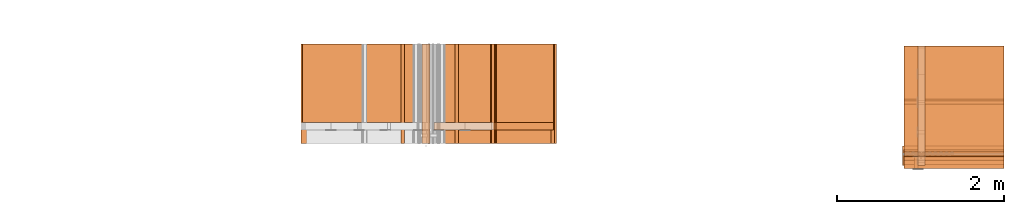
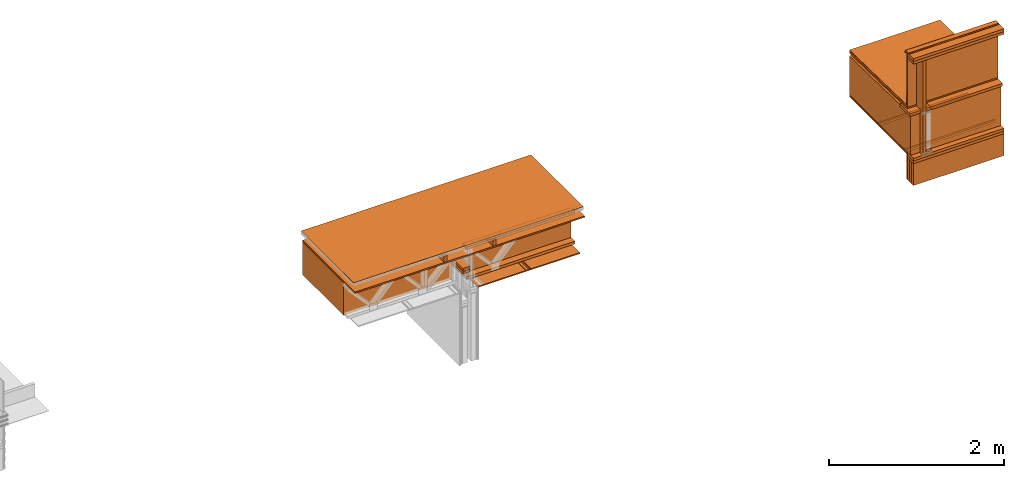
# One storey, part 5 of 22: 34 proxies.
"""IFC2X3 building model written with IfcOpenShell, lengths in feet."""

from ifc_helpers import new_model, entity, si_unit, converted_unit, frame, frame_2d, origin_with_axes, place, context, subcontext, project, spatial, polyline, rectangle, outline, extrude, element, save


model = new_model("IFC2X3")

# Units and contexts
model_context = context("Model", 3, precision=1e-05)
plan_context = context("Plan", 2, precision=1e-05, world=frame_2d((0.0, 0.0, 0.0), x_axis=(1.0, 0.0, 0.0)))
body_context_1 = subcontext(model_context, "Body", "Model", "MODEL_VIEW")
body_context_2 = subcontext(model_context, "Body", "Model", "MODEL_VIEW")
ifc_project = project(units=[converted_unit("VOLUMEUNIT", "cubic foot", entity("IfcReal", 0.0283168467116885), si_unit("VOLUMEUNIT", "CUBIC_METRE"), dimensions=[3, 0, 0, 0, 0, 0, 0]), converted_unit("AREAUNIT", "square foot", entity("IfcReal", 0.09290304), si_unit("AREAUNIT", "SQUARE_METRE"), dimensions=[2, 0, 0, 0, 0, 0, 0]), converted_unit("LENGTHUNIT", "foot", entity("IfcReal", 0.3048), si_unit("LENGTHUNIT", "METRE"), dimensions=[1, 0, 0, 0, 0, 0, 0])], contexts=[model_context, plan_context])

# Site, building, storey
site_placement = place(None, origin_with_axes())
site = spatial("IfcSite", under=ifc_project, at=site_placement, CompositionType="ELEMENT")
building_placement = place(site_placement, origin_with_axes())
building = spatial("IfcBuilding", under=site, at=building_placement, Name="Building", CompositionType="ELEMENT")
storey_placement = place(building_placement, origin_with_axes())
storey = spatial("IfcBuildingStorey", under=building, at=storey_placement, Name="Storey", CompositionType="ELEMENT")

# Proxies
proxy_1_placement = place(storey_placement, frame((1658.61945765538, 1.89104828778214, -61.6842117209447), z_axis=(0.0, 0.0, 1.0), x_axis=(-1.62920684942947e-07, 1.0, 0.0)))
element("IfcBuildingElementProxy", 1, at=proxy_1_placement, inside=storey, Name="Dowel60:Dowel", context=body_context_1, shape_type="SweptSolid", body=[
    extrude(outline(polyline([(-0.0916404852501833, -0.0212016241048069), (0.0303085609840283, -0.0212016241048069), (0.0667668820366146, 0.0152567168086611), (0.106276188955063, 0.015256727502982), (0.106276188955063, 0.020465054280391), (0.0646095380695473, 0.0204650527526309), (0.0281511925727989, -0.0159932835775567), (-0.0894831229499945, -0.0159932881608371), (-0.108790979903983, 0.00331455657107076), (-0.112473822915022, -0.00036828794385694), (-0.0916404852501833, -0.0212016241048069)])), frame((7.80471750220128e-07, -0.112483172807011, 0.0211991888551613), z_axis=(-1.0, -2.10234702535672e-05, -1.15315297080087e-05), x_axis=(2.10234720725566e-05, -1.0, -1.98194598510781e-08)), (1.86355100595392e-05, -1.09133670775918e-05, -1.0), 3.92583333463605),
])
proxy_2_placement = place(storey_placement, frame((1652.54157359206, 1.89104789667555, -61.7362946037232), z_axis=(0.0, 0.0, 1.0), x_axis=(1.0, 0.0, 0.0)))
element("IfcBuildingElementProxy", 2, at=proxy_2_placement, inside=storey, Name="Generic Models 847:Generic Models 1:245", context=body_context_1, shape_type="SweptSolid", body=[
    extrude(rectangle(XDim=4.43021606574954, YDim=3.92583333372057, at=frame_2d((0.0, 0.0, 0.0))), frame((6.22892942954236, 1.96291666644139, 0.0), z_axis=(0.0, 0.0, -1.0), x_axis=(0.999999940395355, 0.0, 0.0)), (0.0, 0.0, -1.0), 0.0520833335148361),
])
proxy_3_placement = place(storey_placement, frame((1651.993298468, 7.65793749040819, -59.9454707048071), z_axis=(-3.89414367418794e-07, 1.0, -1.62920684942947e-07), x_axis=(-1.0, -3.89414367418794e-07, -7.36919087627715e-15)))
element("IfcBuildingElementProxy", 3, at=proxy_3_placement, inside=storey, Name="Plane", context=body_context_1, shape_type="SweptSolid", body=[
    extrude(outline(polyline([(-2.35047103382471, -0.749991038261749), (2.35047924706316, -0.749991038261749), (2.3504714249313, 0.750003358119429), (-2.35047905150987, 0.749978327297476), (-2.35047103382471, -0.749991038261749)])), frame((-1.56912082449345, -0.947072632669464, -4.94139009886213), z_axis=(0.0, 0.0, -1.0), x_axis=(1.0, 5.3246303650667e-06, 0.0)), (1.39559645617737e-07, -7.72574892948796e-08, -1.0), 3.10033562211462),
])
proxy_4_placement = place(storey_placement, frame((1654.28802410136, 1.89106295427938, -60.0035359540324), z_axis=(-0.0623933188617229, 0.998051643371582, -7.58967132696853e-07), x_axis=(-0.998051643371582, -0.0623933188617229, -1.47461420851869e-07)))
element("IfcBuildingElementProxy", 4, at=proxy_4_placement, inside=storey, Name="Generic Models 849:Generic Models 1", context=body_context_1, shape_type="SweptSolid", body=[
    extrude(outline(polyline([(4.98456513787818, 7.67908338258737e-09), (4.98456474677158, 0.00935665461946074), (-4.98488115200533, 0.000311636831802365), (-4.98424795043124, -0.00966831004696842), (4.98456513787818, 7.67908338258737e-09)])), frame((-1.85528217651087, 0.365522404120663, -0.115972784716939), z_axis=(0.0623999424278736, 1.66406334756175e-05, -0.998051285743713), x_axis=(-0.998050689697266, -0.000969853426795453, -0.0623999498784542)), (6.8706026468135e-06, 1.65439741977025e-05, -1.0), 3.92583366120034),
])
proxy_5_placement = place(storey_placement, frame((1654.36702137544, 1.89104789667555, -60.1425383660424), z_axis=(0.0, 0.0, 1.0), x_axis=(1.0, 0.0, 0.0)))
element("IfcBuildingElementProxy", 5, at=proxy_5_placement, inside=storey, Name="Generic Models 841:Generic Models 1:245", context=body_context_1, shape_type="SweptSolid", body=[
    extrude(rectangle(XDim=9.96871498681381, YDim=3.92583333372057, at=frame_2d((0.0, 0.0, 0.0))), frame((1.84589288053237, 1.96291666644139, 0.0), z_axis=(0.0, 0.0, -1.0), x_axis=(-1.0, 0.0, 0.0)), (0.0, 0.0, -1.0), 0.0625000001175565),
])
proxy_6_placement = place(storey_placement, frame((1657.15966011908, 0.875493770665697, -59.9454707048071), z_axis=(0.0, 0.0, 1.0), x_axis=(1.0, 0.0, 0.0)))
element("IfcBuildingElementProxy", 6, at=proxy_6_placement, inside=storey, Name="Plane", context=body_context_1, shape_type="SweptSolid", body=[
    extrude(rectangle(XDim=3.10033562211458, YDim=4.70094978133192, at=frame_2d((0.0, 0.0, 0.0))), frame((1.56912062894015, 3.39122229986616, -1.69706332871294), z_axis=(0.0, 0.0, -1.0), x_axis=(0.0, -1.0, 0.0)), (0.0, 0.0, -1.0), 1.49999431547957),
])
proxy_7_placement = place(storey_placement, frame((1656.378297981, 1.89104809222885, -61.6425416600986), z_axis=(0.0, 0.0, 1.0), x_axis=(1.0, 0.0, 0.0)))
element("IfcBuildingElementProxy", 7, at=proxy_7_placement, inside=storey, Name="Generic Models 855:Generic Models 1", context=body_context_1, shape_type="SweptSolid", body=[
    extrude(rectangle(XDim=0.291666561478815, YDim=4.701001915869, at=frame_2d((0.0, 0.0, 0.0))), frame((2.35049430466699, 0.679666601766751, 8.21173307247166e-06), z_axis=(0.0, 0.0, -1.0), x_axis=(0.0, 1.0, 0.0)), (0.0, 0.0, -1.0), 0.125000015272121),
])
proxy_8_placement = place(storey_placement, frame((1656.378297981, 2.42488140978525, -60.1425383660424), z_axis=(0.0, 0.0, 1.0), x_axis=(1.0, 0.0, 0.0)))
element("IfcBuildingElementProxy", 8, at=proxy_8_placement, inside=storey, Name="Generic Models 855:Generic Models 1", context=body_context_1, shape_type="SweptSolid", body=[
    extrude(rectangle(XDim=0.291666664589754, YDim=4.701001915869, at=frame_2d((0.0, 0.0, 0.0))), frame((2.35051346889005, 0.145833333098669, -0.124997667127394), z_axis=(0.0, 0.0, -1.0), x_axis=(0.0, 1.0, 0.0)), (0.0, 0.0, -1.0), 0.125000015272121),
])
for number, where, z_axis, x_axis, name in (
    (9, (1657.09778392722, 1.89105591436071, -59.7883459777031), (1.0, 4.01339377731347e-07, -4.01339264044509e-07), (-4.01339264044509e-07, 1.0, 2.68220873067548e-07), "Generic Models 857:Generic Models 1"),
    (10, (1654.97266714341, 1.89105591436071, -59.7883459777031), (1.0, 4.01339377731347e-07, -4.01339264044509e-07), (-4.01339264044509e-07, 1.0, 2.68220873067548e-07), "Generic Models 857:Generic Models 1"),
):
    element("IfcBuildingElementProxy", number, at=place(storey_placement, frame(where, z_axis=z_axis, x_axis=x_axis)), inside=storey, Name=name, context=body_context_1, shape_type="SweptSolid", body=[
        extrude(rectangle(XDim=0.291681873054029, YDim=3.92583333372057, at=frame_2d((0.0, 0.0, 0.0))), frame((1.96291666644139, -0.145840935233071, 0.125000001544871), z_axis=(0.0, 0.0, -1.0), x_axis=(0.0, 1.0, 0.0)), (0.0, 0.0, -1.0), 0.125000000235113),
    ])
proxy_9_placement = place(storey_placement, frame((1674.88038070559, 3.43246253456656, -61.6841992055337), z_axis=(0.0, 0.0, 1.0), x_axis=(-4.37113882867379e-08, -1.0, 0.0)))
element("IfcBuildingElementProxy", 11, at=proxy_9_placement, inside=storey, Name="Dowel60:Dowel", context=body_context_1, shape_type="SweptSolid", body=[
    extrude(outline(polyline([(-0.0303086098723524, -0.0212016561877696), (0.0916403813624945, -0.0212016561877696), (0.112473664027969, -0.000368311266070158), (0.108790808794849, 0.00331452525198812), (0.0894830373954272, -0.0159933187160397), (-0.0281512628497649, -0.0159932576056345), (-0.0646096236241145, 0.0204650833078335), (-0.106276360064197, 0.0204650817800734), (-0.106276360064197, 0.0152567458361035), (-0.0667669675911818, 0.0152567534749042), (-0.0303086098723524, -0.0212016561877696)])), frame((1.88752637291205, 3.88253279045491e-07, 0.0212016806319317), z_axis=(-3.16891434967714e-12, -1.0, -3.20355102303438e-05), x_axis=(1.0, -1.37635207050901e-11, 3.37055979571232e-07)), (-1.47629222624346e-07, -3.20263388857711e-05, -1.0), 3.92583333573395),
])
proxy_10_placement = place(storey_placement, frame((1674.88038070559, 5.43242520860487, -61.6841992055337), z_axis=(0.0, 0.0, 1.0), x_axis=(-4.37113882867379e-08, -1.0, 0.0)))
element("IfcBuildingElementProxy", 12, at=proxy_10_placement, inside=storey, Name="Dowel60:Dowel", context=body_context_1, shape_type="SweptSolid", body=[
    extrude(outline(polyline([(-0.0281511681286369, 0.0159932866330769), (0.0894831351720755, 0.0159932866330769), (0.108790894349416, -0.00331455924465099), (0.112473749582536, 0.000368279326334962), (0.0916404791391428, 0.0212016286880873), (-0.0303085120957042, 0.0212016164660063), (-0.0667668820366146, -0.0152567229197016), (-0.10627627450963, -0.0152567183364212), (-0.10627627450963, -0.0204650558081512), (-0.0646095380695473, -0.0204650527526309), (-0.0281511681286369, 0.0159932866330769)])), frame((1.88752559069886, 3.92583411509596, 0.0212016439656886), z_axis=(8.27671010483755e-06, 1.0, -0.000168188562383875), x_axis=(1.0, -6.6495331338956e-06, -9.74052660751568e-09)), (6.62493175696e-06, 0.000168192476849072, -1.0), 3.92583371618496),
])
for number, where, z_axis, x_axis, name in (
    (13, (1674.88038070559, 1.05974105555867, -62.7675331796561), (0.0, 0.0, 1.0), (-4.37113882867379e-08, -1.0, 0.0), "Generic Models 857:Generic Models 1"),
    (14, (1674.88038070559, 0.907253288221484, -62.7675331796561), (0.0, 0.0, 1.0), (-4.37113882867379e-08, -1.0, 0.0), "Generic Models 857:Generic Models 1"),
    (15, (1674.88038070559, 0.753864411293991, -62.7675331796561), (0.0, 0.0, 1.0), (-4.37113882867379e-08, -1.0, 0.0), "Generic Models 857:Generic Models 1"),
):
    element("IfcBuildingElementProxy", number, at=place(storey_placement, frame(where, z_axis=z_axis, x_axis=x_axis)), inside=storey, Name=name, context=body_context_1, shape_type="SweptSolid", body=[
        extrude(rectangle(XDim=3.92583333372062, YDim=0.152474618603812, at=frame_2d((0.0, 0.0, 0.0))), frame((-0.244431207420945, 1.96291666644139, -0.124999744881169), z_axis=(3.20632494776874e-07, 1.61888749516947e-07, -1.0), x_axis=(0.0, 1.0, 1.61888735306093e-07)), (-2.49453904643815e-07, 2.80553450693333e-07, -1.0), 1.00000000188097),
    ])
proxy_11_placement = place(storey_placement, frame((1674.88038070559, 4.68380338563694, -59.7213447250406), z_axis=(-3.97786237726905e-07, 0.0209428239613771, 0.999780654907227), x_axis=(-4.37018030652325e-08, -0.999780654907227, 0.0209428239613771)))
element("IfcBuildingElementProxy", 16, at=proxy_11_placement, inside=storey, Name="Generic Models 841:Generic Models 1:245", context=body_context_1, shape_type="SweptSolid", body=[
    extrude(rectangle(XDim=4.346574440544, YDim=3.92583333372057, at=frame_2d((0.0, 0.0, 0.0))), frame((1.13210516182456, 1.96291666644139, 0.0), z_axis=(0.0, 0.0, -1.0), x_axis=(-1.0, 0.0, 0.0)), (0.0, 0.0, -1.0), 0.0625000001175565),
])
proxy_12_placement = place(storey_placement, frame((1674.88038070559, 0.922071534817613, -57.0800360732191), z_axis=(0.0, 0.0, 1.0), x_axis=(-4.37113882867379e-08, -1.0, 0.0)))
element("IfcBuildingElementProxy", 17, at=proxy_12_placement, inside=storey, Name="Generic Models 857:Generic Models 1", context=body_context_1, shape_type="SweptSolid", body=[
    extrude(rectangle(XDim=3.92583333372062, YDim=0.458337028879998, at=frame_2d((0.0, 0.0, 0.0))), frame((-0.22916851707018, 1.96291666644139, -0.124999744881169), z_axis=(2.39995301853924e-07, 1.5877549230936e-07, -1.0), x_axis=(0.0, -1.0, -1.5877549230936e-07)), (-3.58418373105907e-13, -1.95553198523157e-07, -1.0), 0.125000025296795),
])
proxy_13_placement = place(storey_placement, frame((1674.88038070559, 0.701900424919729, -57.3500060033923), z_axis=(0.0, 0.0, 1.0), x_axis=(-4.37113882867379e-08, -1.0, 0.0)))
element("IfcBuildingElementProxy", 18, at=proxy_13_placement, inside=storey, Name="Walls 112:Walls 26", context=body_context_1, shape_type="SweptSolid", body=[
    extrude(outline(polyline([(0.0417969168806717, 0.000610227499210967), (0.108128054228824, 0.000610215277129936), (0.108128090895067, 0.00717190263567986), (0.0435450166864736, 0.00717185985839625), (0.0407234637257386, 0.00756131647047135), (0.0381128149952867, 0.00870047553303087), (-0.0213410933269799, 0.0450373938908492), (-0.029217028315729, 0.0462752584798208), (-0.0356614383137993, 0.0415814660362449), (-0.146568197942781, -0.139882621841794), (-0.141013139893064, -0.143277744843265), (-0.0307853168653926, 0.037075380313154), (-0.0275631851988436, 0.0394221909803747), (-0.0236252536068321, 0.0388032892410915), (0.0363646540790796, 0.00213879428552146), (0.0389753150316126, 0.000999623000880904), (0.0417969168806717, 0.000610227499210967)])), frame((-0.809307633031385, 3.92583372398937, 0.237082656756474), z_axis=(-5.90927902521798e-06, 1.0, 4.6693135118403e-06), x_axis=(-0.521491348743439, -2.94813598884502e-05, -0.853256523609161)), (6.20781020188588e-06, 2.55379472946515e-05, -1.0), 3.92583366192626),
])
for number, where, z_axis, x_axis, name in (
    (19, (1674.88038070559, 0.922071534817613, -57.2050337403465), (0.0, 0.0, 1.0), (-4.37113882867379e-08, -1.0, 0.0), "Generic Models 857:Generic Models 1"),
    (20, (1674.88038070559, 0.922071534817613, -61.6425354023931), (0.0, 0.0, 1.0), (-4.37113882867379e-08, -1.0, 0.0), "Generic Models 857:Generic Models 1"),
    (21, (1674.88038070559, 0.922071534817613, -61.7675330695205), (0.0, 0.0, 1.0), (-4.37113882867379e-08, -1.0, 0.0), "Generic Models 857:Generic Models 1"),
):
    element("IfcBuildingElementProxy", number, at=place(storey_placement, frame(where, z_axis=z_axis, x_axis=x_axis)), inside=storey, Name=name, context=body_context_1, shape_type="SweptSolid", body=[
        extrude(rectangle(XDim=3.92583333372062, YDim=0.458337028879998, at=frame_2d((0.0, 0.0, 0.0))), frame((-0.22916851707018, 1.96291666644139, -0.124999744881169), z_axis=(2.39995301853924e-07, 1.5877549230936e-07, -1.0), x_axis=(0.0, 1.0, 1.5877549230936e-07)), (3.58418373105907e-13, 1.95553198523157e-07, -1.0), 0.125000025296795),
    ])
proxy_14_placement = place(storey_placement, frame((1672.34996485272, 1.66789010128011, -57.8829747798249), z_axis=(0.0, 0.0, 1.0), x_axis=(-4.37113882867379e-08, -1.0, 0.0)))
element("IfcBuildingElementProxy", 22, at=proxy_14_placement, inside=storey, Name="Plane", context=body_context_1, shape_type="SweptSolid", body=[
    extrude(rectangle(XDim=0.129999920355563, YDim=0.458287070881728, at=frame_2d((0.0, 0.0, 0.0))), frame((0.516643596133535, 2.99930689841744, -3.75956218699458), z_axis=(0.0, 0.0, -1.0), x_axis=(0.0, 1.0, 0.0)), (0.0, 0.0, -0.999999940395355), 4.31250712841991),
])
proxy_15_placement = place(storey_placement, frame((1673.86483019731, 0.672063685151849, -58.3669457222846), z_axis=(0.0, 0.0, 1.0), x_axis=(-4.37113882867379e-08, -1.0, 0.0)))
element("IfcBuildingElementProxy", 23, at=proxy_15_placement, inside=storey, Name="Plane", context=body_context_1, shape_type="SweptSolid", body=[
    extrude(rectangle(XDim=0.0416667373353818, YDim=3.92583333372057, at=frame_2d((0.0, 0.0, 0.0))), frame((-0.729220980421452, 2.97847343242075, -1.22356250530153), z_axis=(0.0, 0.0, -1.0), x_axis=(-1.0, 0.0, 0.0)), (-3.89475118822702e-08, 0.0, -0.999999940395355), 2.51047214359348),
])
proxy_16_placement = place(storey_placement, frame((1673.86483019731, 2.40199385196205, -57.6130423958846), z_axis=(-0.998051822185516, 0.0623385719954967, 0.00255164527334273), x_axis=(-0.0623907707631588, -0.997216582298279, -0.0408231429755688)))
element("IfcBuildingElementProxy", 24, at=proxy_16_placement, inside=storey, Name="Plane", context=body_context_1, shape_type="SweptSolid", body=[
    extrude(rectangle(XDim=0.0830000892507013, YDim=4.30494964996299, at=frame_2d((0.0, 0.0, 0.0))), frame((-1.39688745414804, -2.02862179185462, -4.86372336940815), z_axis=(-0.0623802728950977, -3.36670325395971e-07, -0.998052477836609), x_axis=(0.0622801221907139, -0.998051106929779, -0.0038922131061554)), (1.45485932989686e-06, -3.42457191493395e-08, -1.0), 3.92583055549985),
])
proxy_17_placement = place(storey_placement, frame((1675.4142380762, 4.88465070098717, -61.5571052070678), z_axis=(-9.56901089921303e-07, 0.0209425874054432, 0.999780595302582), x_axis=(-4.37017995125188e-08, -0.999780595302582, 0.0209425874054432)))
element("IfcBuildingElementProxy", 25, at=proxy_17_placement, inside=storey, Name="Generic Models 855:Generic Models 1", context=body_context_1, shape_type="SweptSolid", body=[
    extrude(rectangle(XDim=4.70100164291481, YDim=0.291666664589754, at=frame_2d((0.0, 0.0, 0.0))), frame((1.54728593006535, 0.145833528651966, 1.70833482517032), z_axis=(0.0, 0.0, -1.0), x_axis=(1.0, 0.0, 0.0)), (0.0, 0.0, -1.0), 0.125000015272121),
])
proxy_18_placement = place(storey_placement, frame((1675.4142380762, 4.92389902980935, -61.6425354023931), z_axis=(0.0, 0.0, 1.0), x_axis=(-4.37113882867379e-08, -1.0, 0.0)))
element("IfcBuildingElementProxy", 26, at=proxy_18_placement, inside=storey, Name="Generic Models 855:Generic Models 1", context=body_context_1, shape_type="SweptSolid", body=[
    extrude(rectangle(XDim=4.70100164291481, YDim=0.291666664589754, at=frame_2d((0.0, 0.0, 0.0))), frame((1.54728593006535, 0.145833528651966, 0.0), z_axis=(0.0, 0.0, -1.0), x_axis=(1.0, 0.0, 0.0)), (0.0, 0.0, -1.0), 0.125000000235113),
])
proxy_19_placement = place(storey_placement, frame((1673.86483019731, 1.8074617689363, -59.9454707048071), z_axis=(-1.0, 4.3711398944879e-08, -1.62920684942947e-07), x_axis=(-4.37113882867379e-08, -1.0, -5.96046376699633e-08)))
element("IfcBuildingElementProxy", 27, at=proxy_19_placement, inside=storey, Name="Plane", context=body_context_1, shape_type="SweptSolid", body=[
    extrude(outline(polyline([(-2.27160732264281, -0.912065170411988), (2.30981022354186, -0.912065170411988), (2.27060315646525, 0.960018554228184), (-2.3088060573643, 0.864111493265848), (-2.27160732264281, -0.912065170411988)])), frame((-1.62938937271048, -0.784798400608573, -4.94139009886213), z_axis=(0.0, 0.0, -1.0), x_axis=(0.999780774116516, 0.0209385100752115, 0.0)), (8.32789055493777e-08, -5.37032178726804e-08, -1.0), 3.92585212754311),
])
proxy_20_placement = place(storey_placement, frame((1674.88038070559, 1.43250005608156, -63.2148777718932), z_axis=(0.0, 0.0, 1.0), x_axis=(-4.37113882867379e-08, -1.0, 0.0)))
element("IfcBuildingElementProxy", 28, at=proxy_20_placement, inside=storey, Name="Generic Models 845:Generic Models 1", context=body_context_1, shape_type="SweptSolid", body=[
    extrude(rectangle(XDim=3.92583333372062, YDim=0.0520833154704227, at=frame_2d((0.0, 0.0, 0.0))), frame((0.0260413466681411, 1.96291666644139, 0.322346925109703), z_axis=(0.0, 0.0, -1.0), x_axis=(1.63445363909887e-07, -1.0, 0.0)), (3.6811558246086e-09, 0.0, -1.0), 1.15625032746861),
])
proxy_21_placement = place(storey_placement, frame((1674.88038070559, 4.64425468695132, -61.7362820883123), z_axis=(0.0, 0.0, 1.0), x_axis=(-4.37113882867379e-08, -1.0, 0.0)))
element("IfcBuildingElementProxy", 29, at=proxy_21_placement, inside=storey, Name="Generic Models 847:Generic Models 1:245", context=body_context_1, shape_type="SweptSolid", body=[
    extrude(rectangle(XDim=4.34660765169413, YDim=3.92583333372057, at=frame_2d((0.0, 0.0, 0.0))), frame((1.09047049612511, 1.96291666644139, 0.0), z_axis=(0.0, 0.0, -1.0), x_axis=(-1.0, 0.0, 0.0)), (0.0, 0.0, -1.0), 0.0520833335148361),
])
proxy_22_placement = place(storey_placement, frame((1674.88038070559, 4.69912224867212, -59.8682193305549), z_axis=(0.998051643371582, 0.0623931549489498, -7.58967132696853e-07), x_axis=(-0.0623931549489498, 0.998051643371582, -1.47461406641014e-07)))
element("IfcBuildingElementProxy", 30, at=proxy_22_placement, inside=storey, Name="Generic Models 849:Generic Models 1", context=body_context_1, shape_type="SweptSolid", body=[
    extrude(outline(polyline([(2.88026578470165, -3.74778656636089e-09), (2.88059705198593, 0.00999448148734144), (-1.41365067383123, 0.328457452298149), (-1.47657845355081, -0.327815841932309), (-1.46664542163138, -0.328767819823868), (-1.40398770101427, 0.318131822691815), (2.88026578470165, -3.74778656636089e-09)])), frame((-1.83485389694454, 0.552786489718855, -0.11470639379084), z_axis=(0.0624103397130966, 8.3761551650241e-06, -0.998050570487976), x_axis=(0.993498563766479, -0.0953995734453201, 0.0621248111128807)), (-2.42833067432002e-07, -8.90582487045322e-06, -1.0), 3.92583415100096),
])
proxy_23_placement = place(storey_placement, frame((1674.88038070559, 1.44101053554555, -58.8989633274829), z_axis=(1.0, -4.37113882867379e-08, -1.62920684942947e-07), x_axis=(-4.37113882867379e-08, -1.0, 0.0)))
element("IfcBuildingElementProxy", 31, at=proxy_23_placement, inside=storey, Name="Vert", context=body_context_2, shape_type="SweptSolid", body=[
    extrude(outline(polyline([(-0.66408990171012, 0.0241535484761469), (1.07633795716318, 0.0241535484761469), (1.07633795716318, -0.142513131453922), (1.08154651921565, -0.14251310700976), (1.08154632366235, 0.0293947037632071), (-0.66118500637883, 0.0293946915411261), (-0.682018325710547, 0.0471030203063344), (-0.811775955628222, 0.0471030050287331), (-0.811775955628222, 0.0418618619637539), (-0.684923221041837, 0.0418618802968755), (-0.66408990171012, 0.0241535484761469)])), frame((0.0430676435900173, -0.742585728252967, -3.01397592448043e-05), z_axis=(-1.42995020269154e-07, 4.33896794049815e-08, -1.0), x_axis=(-6.14465056614222e-09, -1.0, -4.33811635502934e-08)), (1.20185097784997e-06, -1.96734106339136e-07, -1.0), 3.92582941152309),
])
proxy_24_placement = place(storey_placement, frame((1678.60616849163, 1.80690561536103, -59.6521219869298), z_axis=(-1.0, 4.37113882867379e-08, -4.37113882867379e-08), x_axis=(-4.37113882867379e-08, -1.0, 0.0)))
element("IfcBuildingElementProxy", 32, at=proxy_24_placement, inside=storey, Name="Plane", context=body_context_1, shape_type="SweptSolid", body=[
    extrude(rectangle(XDim=0.77083334645607, YDim=0.125000015272124, at=frame_2d((0.0, 0.0, 0.0))), frame((0.385374534787155, -0.0625021335255755, -0.199999958472302), z_axis=(0.0, -1.95553283788286e-07, -1.0), x_axis=(-1.0, 0.0, 0.0)), (0.0, -6.6610333249173e-08, -1.0), 3.99999968673409),
])
for number, where, z_axis, x_axis, name in (
    (33, (1655.91312518583, 1.89104770112225, -60.8925306265123), (0.0, 0.0, 1.0), (-1.62920684942947e-07, 1.0, 0.0), "Generic Models 857:Generic Models 1"),
    (34, (1655.91312518583, 1.89104770112225, -61.0175345513451), (0.0, 0.0, 1.0), (-1.62920684942947e-07, 1.0, 0.0), "Generic Models 857:Generic Models 1"),
):
    element("IfcBuildingElementProxy", number, at=place(storey_placement, frame(where, z_axis=z_axis, x_axis=x_axis)), inside=storey, Name=name, context=body_context_1, shape_type="SweptSolid", body=[
        extrude(rectangle(XDim=0.309003192623603, YDim=3.92583333372057, at=frame_2d((0.0, 0.0, 0.0))), frame((1.96291666644139, -0.154501599628781, 0.125000001544871), z_axis=(0.0, 0.0, -1.0), x_axis=(0.0, -0.999999940395355, 0.0)), (0.0, 0.0, -1.0), 0.125000000235113),
    ])

save(model, "model.ifc")
